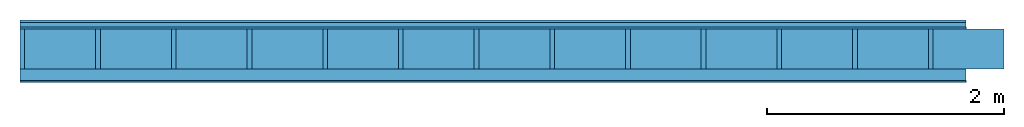
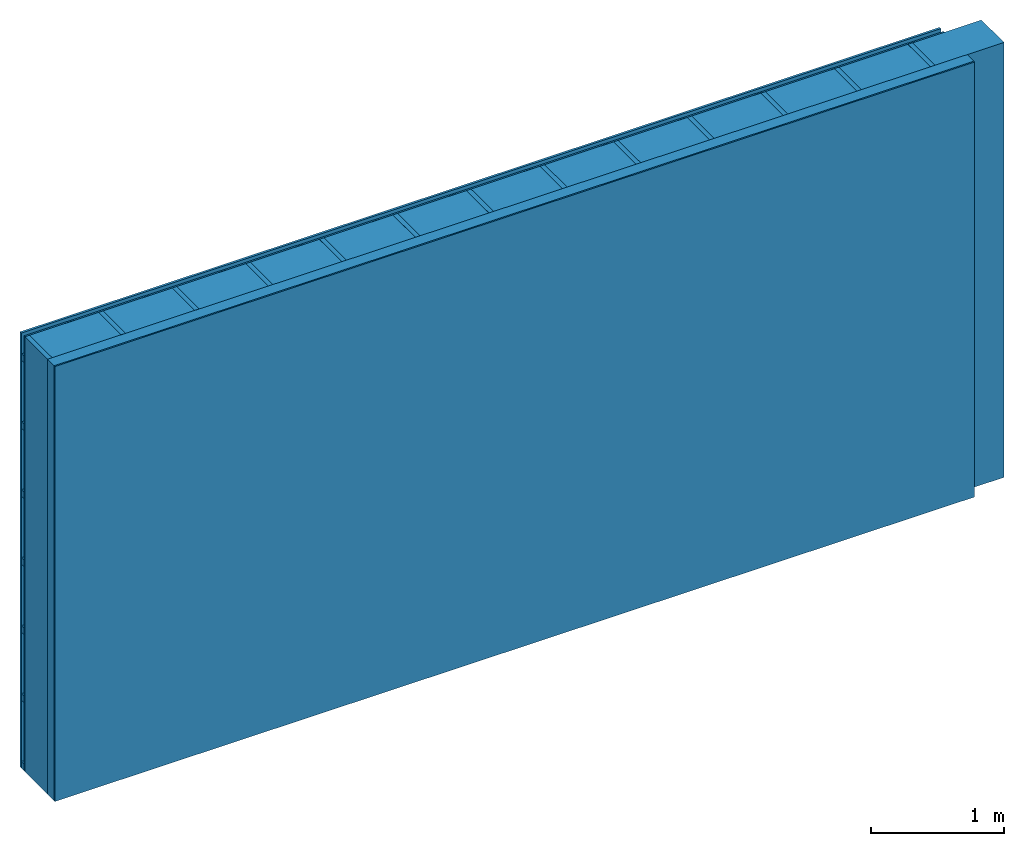
# One storey: 4 plates, 3 members, 1 element without a shape of its own.
"""IFC4 building model written with IfcOpenShell, lengths in metres."""

from ifc_helpers import new_model, si_unit, derived_unit, direction, frame, frame_2d, origin, origin_with_axes, place, context, project, spatial, rectangle, extrude, material, layer, layer_set, type_object, element, aggregate, save


model = new_model("IFC4")

# Units and contexts
plan_context = context("Plan", 3, precision=1e-05, world=origin(), true_north=direction((0.0, 1.0)))
model_context = context("Model", 3, precision=1e-05, world=origin(), true_north=direction((0.0, 1.0)))
ifc_project = project(units=[si_unit("LENGTHUNIT", "METRE"), derived_unit("SOUNDPRESSUREUNIT", [(si_unit("PRESSUREUNIT", "PASCAL", prefix="MICRO"), 0)]), si_unit("ENERGYUNIT", "JOULE", prefix="MEGA"), si_unit("MASSUNIT", "GRAM", prefix="KILO"), derived_unit("THERMALTRANSMITTANCEUNIT", [(si_unit("POWERUNIT", "WATT"), 1), (si_unit("AREAUNIT", "SQUARE_METRE"), -1), (si_unit("THERMODYNAMICTEMPERATUREUNIT", "KELVIN"), -1)]), derived_unit("AREADENSITYUNIT", [(si_unit("MASSUNIT", "GRAM", prefix="KILO"), 1), (si_unit("AREAUNIT", "SQUARE_METRE"), -1)]), derived_unit("USERDEFINED", [(si_unit("ENERGYUNIT", "JOULE", prefix="MEGA"), 1), (si_unit("AREAUNIT", "SQUARE_METRE"), -1)])], contexts=[plan_context, model_context])

# Site, building, storey
site = spatial("IfcSite", under=ifc_project)
building_placement = place(None, origin())
building = spatial("IfcBuilding", under=site, at=building_placement)
storey_placement = place(building_placement, origin())
storey = spatial("IfcBuildingStorey", under=building, at=storey_placement)

# Wall, members, plates
ifc_material_1 = material(Name="Wood cladding horizontal, closed")
ifc_layer_1 = layer(ifc_material_1, 0.02, Name="Cover 1st layer")
ifc_layer_2 = layer(None, 0.04, Name="Battens / profiles (ventilation)")
ifc_material_2 = material(Category="03.007")
ifc_layer_3 = layer(ifc_material_2, 0.015, Name="outside 1st layer")
ifc_material_3 = material(Name="of the art")
ifc_layer_4 = layer(ifc_material_3, 0.0, Name="Bond")
ifc_layer_5 = layer(None, 0.34, Name="Support")
ifc_layer_6 = layer(ifc_material_3, 0.0, Name="Bond")
ifc_material_4 = material(Name="Solid timber panel")
ifc_layer_7 = layer(ifc_material_4, 0.1, Name="1st layer")
ifc_material_5 = material(Name="Plasterboard type A", Category="03.008")
ifc_layer_8 = layer(ifc_material_5, 0.0125, Name="Covering 1st layer")
ifc_material_6 = material(Name="joints", Category="04.017")
ifc_layer_9 = layer(ifc_material_6, 0.0, Name="Surface")
ifc_layer_set = layer_set([ifc_layer_1, ifc_layer_2, ifc_layer_3, ifc_layer_4, ifc_layer_5, ifc_layer_6, ifc_layer_7, ifc_layer_8, ifc_layer_9])
wall_type = type_object("IfcWallType", Name="D0993", PredefinedType="NOTDEFINED", material=ifc_layer_set)
wall_placement = place(None, frame((0.0, 0.0, 0.0), z_axis=(0.0, -1.0, 0.0), x_axis=(1.0, 0.0, 0.0)))
wall = element("IfcWall", 1, at=wall_placement, inside=storey, type_object=wall_type, material=ifc_layer_set, Name="Wall #1")
ifc_material_7 = material()
member_1_placement = place(wall_placement, origin())
member_1 = element("IfcMember", 2, at=member_1_placement, material=ifc_material_7, Name="Battens / profiles (ventilation)", context=plan_context, shape_type="SweptSolid", body=[
    extrude(rectangle(XDim=0.06, YDim=0.04, at=frame_2d((0.03, 0.02), x_axis=(1.0, 0.0))), frame((0.0, 0.0, 0.02), z_axis=(1.0, 0.0, 0.0), x_axis=(0.0, 1.0, 0.0)), (0.0, 0.0, 1.0), 8.0),
    extrude(rectangle(XDim=0.06, YDim=0.04, at=frame_2d((0.03, 0.02), x_axis=(1.0, 0.0))), frame((0.0, 0.625, 0.02), z_axis=(1.0, 0.0, 0.0), x_axis=(0.0, 1.0, 0.0)), (0.0, 0.0, 1.0), 8.0),
    extrude(rectangle(XDim=0.06, YDim=0.04, at=frame_2d((0.03, 0.02), x_axis=(1.0, 0.0))), frame((0.0, 1.25, 0.02), z_axis=(1.0, 0.0, 0.0), x_axis=(0.0, 1.0, 0.0)), (0.0, 0.0, 1.0), 8.0),
    extrude(rectangle(XDim=0.06, YDim=0.04, at=frame_2d((0.03, 0.02), x_axis=(1.0, 0.0))), frame((0.0, 1.875, 0.02), z_axis=(1.0, 0.0, 0.0), x_axis=(0.0, 1.0, 0.0)), (0.0, 0.0, 1.0), 8.0),
    extrude(rectangle(XDim=0.06, YDim=0.04, at=frame_2d((0.03, 0.02), x_axis=(1.0, 0.0))), frame((0.0, 2.5, 0.02), z_axis=(1.0, 0.0, 0.0), x_axis=(0.0, 1.0, 0.0)), (0.0, 0.0, 1.0), 8.0),
    extrude(rectangle(XDim=0.06, YDim=0.04, at=frame_2d((0.03, 0.02), x_axis=(1.0, 0.0))), frame((0.0, 3.125, 0.02), z_axis=(1.0, 0.0, 0.0), x_axis=(0.0, 1.0, 0.0)), (0.0, 0.0, 1.0), 8.0),
    extrude(rectangle(XDim=0.06, YDim=0.04, at=frame_2d((0.03, 0.02), x_axis=(1.0, 0.0))), frame((0.0, 3.75, 0.02), z_axis=(1.0, 0.0, 0.0), x_axis=(0.0, 1.0, 0.0)), (0.0, 0.0, 1.0), 8.0),
])
ifc_material_8 = material()
member_2_placement = place(wall_placement, origin())
member_2 = element("IfcMember", 3, at=member_2_placement, material=ifc_material_8, Name="Support", context=plan_context, shape_type="SweptSolid", body=[
    extrude(rectangle(XDim=0.04, YDim=0.34, at=frame_2d((0.02, 0.17), x_axis=(1.0, 0.0))), frame((0.0, 4.0, 0.075), z_axis=(0.0, -1.0, 0.0), x_axis=(1.0, 0.0, 0.0)), (0.0, 0.0, 1.0), 4.0),
    extrude(rectangle(XDim=0.04, YDim=0.34, at=frame_2d((0.02, 0.17), x_axis=(1.0, 0.0))), frame((0.64, 4.0, 0.075), z_axis=(0.0, -1.0, 0.0), x_axis=(1.0, 0.0, 0.0)), (0.0, 0.0, 1.0), 4.0),
    extrude(rectangle(XDim=0.04, YDim=0.34, at=frame_2d((0.02, 0.17), x_axis=(1.0, 0.0))), frame((1.28, 4.0, 0.075), z_axis=(0.0, -1.0, 0.0), x_axis=(1.0, 0.0, 0.0)), (0.0, 0.0, 1.0), 4.0),
    extrude(rectangle(XDim=0.04, YDim=0.34, at=frame_2d((0.02, 0.17), x_axis=(1.0, 0.0))), frame((1.92, 4.0, 0.075), z_axis=(0.0, -1.0, 0.0), x_axis=(1.0, 0.0, 0.0)), (0.0, 0.0, 1.0), 4.0),
    extrude(rectangle(XDim=0.04, YDim=0.34, at=frame_2d((0.02, 0.17), x_axis=(1.0, 0.0))), frame((2.56, 4.0, 0.075), z_axis=(0.0, -1.0, 0.0), x_axis=(1.0, 0.0, 0.0)), (0.0, 0.0, 1.0), 4.0),
    extrude(rectangle(XDim=0.04, YDim=0.34, at=frame_2d((0.02, 0.17), x_axis=(1.0, 0.0))), frame((3.2, 4.0, 0.075), z_axis=(0.0, -1.0, 0.0), x_axis=(1.0, 0.0, 0.0)), (0.0, 0.0, 1.0), 4.0),
    extrude(rectangle(XDim=0.04, YDim=0.34, at=frame_2d((0.02, 0.17), x_axis=(1.0, 0.0))), frame((3.84, 4.0, 0.075), z_axis=(0.0, -1.0, 0.0), x_axis=(1.0, 0.0, 0.0)), (0.0, 0.0, 1.0), 4.0),
    extrude(rectangle(XDim=0.04, YDim=0.34, at=frame_2d((0.02, 0.17), x_axis=(1.0, 0.0))), frame((4.48, 4.0, 0.075), z_axis=(0.0, -1.0, 0.0), x_axis=(1.0, 0.0, 0.0)), (0.0, 0.0, 1.0), 4.0),
    extrude(rectangle(XDim=0.04, YDim=0.34, at=frame_2d((0.02, 0.17), x_axis=(1.0, 0.0))), frame((5.12, 4.0, 0.075), z_axis=(0.0, -1.0, 0.0), x_axis=(1.0, 0.0, 0.0)), (0.0, 0.0, 1.0), 4.0),
    extrude(rectangle(XDim=0.04, YDim=0.34, at=frame_2d((0.02, 0.17), x_axis=(1.0, 0.0))), frame((5.76, 4.0, 0.075), z_axis=(0.0, -1.0, 0.0), x_axis=(1.0, 0.0, 0.0)), (0.0, 0.0, 1.0), 4.0),
    extrude(rectangle(XDim=0.04, YDim=0.34, at=frame_2d((0.02, 0.17), x_axis=(1.0, 0.0))), frame((6.4, 4.0, 0.075), z_axis=(0.0, -1.0, 0.0), x_axis=(1.0, 0.0, 0.0)), (0.0, 0.0, 1.0), 4.0),
    extrude(rectangle(XDim=0.04, YDim=0.34, at=frame_2d((0.02, 0.17), x_axis=(1.0, 0.0))), frame((7.04, 4.0, 0.075), z_axis=(0.0, -1.0, 0.0), x_axis=(1.0, 0.0, 0.0)), (0.0, 0.0, 1.0), 4.0),
    extrude(rectangle(XDim=0.04, YDim=0.34, at=frame_2d((0.02, 0.17), x_axis=(1.0, 0.0))), frame((7.68, 4.0, 0.075), z_axis=(0.0, -1.0, 0.0), x_axis=(1.0, 0.0, 0.0)), (0.0, 0.0, 1.0), 4.0),
])
ifc_material_9 = material(Name="Mineral wool")
member_3_placement = place(wall_placement, origin())
member_3 = element("IfcMember", 4, at=member_3_placement, material=ifc_material_9, Name="Cavity", context=plan_context, shape_type="SweptSolid", body=[
    extrude(rectangle(XDim=0.6, YDim=0.34, at=frame_2d((0.3, 0.17), x_axis=(1.0, 0.0))), frame((0.04, 4.0, 0.075), z_axis=(0.0, -1.0, 0.0), x_axis=(1.0, 0.0, 0.0)), (0.0, 0.0, 1.0), 4.0),
    extrude(rectangle(XDim=0.6, YDim=0.34, at=frame_2d((0.3, 0.17), x_axis=(1.0, 0.0))), frame((0.68, 4.0, 0.075), z_axis=(0.0, -1.0, 0.0), x_axis=(1.0, 0.0, 0.0)), (0.0, 0.0, 1.0), 4.0),
    extrude(rectangle(XDim=0.6, YDim=0.34, at=frame_2d((0.3, 0.17), x_axis=(1.0, 0.0))), frame((1.32, 4.0, 0.075), z_axis=(0.0, -1.0, 0.0), x_axis=(1.0, 0.0, 0.0)), (0.0, 0.0, 1.0), 4.0),
    extrude(rectangle(XDim=0.6, YDim=0.34, at=frame_2d((0.3, 0.17), x_axis=(1.0, 0.0))), frame((1.96, 4.0, 0.075), z_axis=(0.0, -1.0, 0.0), x_axis=(1.0, 0.0, 0.0)), (0.0, 0.0, 1.0), 4.0),
    extrude(rectangle(XDim=0.6, YDim=0.34, at=frame_2d((0.3, 0.17), x_axis=(1.0, 0.0))), frame((2.6, 4.0, 0.075), z_axis=(0.0, -1.0, 0.0), x_axis=(1.0, 0.0, 0.0)), (0.0, 0.0, 1.0), 4.0),
    extrude(rectangle(XDim=0.6, YDim=0.34, at=frame_2d((0.3, 0.17), x_axis=(1.0, 0.0))), frame((3.24, 4.0, 0.075), z_axis=(0.0, -1.0, 0.0), x_axis=(1.0, 0.0, 0.0)), (0.0, 0.0, 1.0), 4.0),
    extrude(rectangle(XDim=0.6, YDim=0.34, at=frame_2d((0.3, 0.17), x_axis=(1.0, 0.0))), frame((3.88, 4.0, 0.075), z_axis=(0.0, -1.0, 0.0), x_axis=(1.0, 0.0, 0.0)), (0.0, 0.0, 1.0), 4.0),
    extrude(rectangle(XDim=0.6, YDim=0.34, at=frame_2d((0.3, 0.17), x_axis=(1.0, 0.0))), frame((4.52, 4.0, 0.075), z_axis=(0.0, -1.0, 0.0), x_axis=(1.0, 0.0, 0.0)), (0.0, 0.0, 1.0), 4.0),
    extrude(rectangle(XDim=0.6, YDim=0.34, at=frame_2d((0.3, 0.17), x_axis=(1.0, 0.0))), frame((5.16, 4.0, 0.075), z_axis=(0.0, -1.0, 0.0), x_axis=(1.0, 0.0, 0.0)), (0.0, 0.0, 1.0), 4.0),
    extrude(rectangle(XDim=0.6, YDim=0.34, at=frame_2d((0.3, 0.17), x_axis=(1.0, 0.0))), frame((5.8, 4.0, 0.075), z_axis=(0.0, -1.0, 0.0), x_axis=(1.0, 0.0, 0.0)), (0.0, 0.0, 1.0), 4.0),
    extrude(rectangle(XDim=0.6, YDim=0.34, at=frame_2d((0.3, 0.17), x_axis=(1.0, 0.0))), frame((6.44, 4.0, 0.075), z_axis=(0.0, -1.0, 0.0), x_axis=(1.0, 0.0, 0.0)), (0.0, 0.0, 1.0), 4.0),
    extrude(rectangle(XDim=0.6, YDim=0.34, at=frame_2d((0.3, 0.17), x_axis=(1.0, 0.0))), frame((7.08, 4.0, 0.075), z_axis=(0.0, -1.0, 0.0), x_axis=(1.0, 0.0, 0.0)), (0.0, 0.0, 1.0), 4.0),
    extrude(rectangle(XDim=0.6, YDim=0.34, at=frame_2d((0.3, 0.17), x_axis=(1.0, 0.0))), frame((7.72, 4.0, 0.075), z_axis=(0.0, -1.0, 0.0), x_axis=(1.0, 0.0, 0.0)), (0.0, 0.0, 1.0), 4.0),
])
plate_1_placement = place(wall_placement, origin())
plate_1 = element("IfcPlate", 5, at=plate_1_placement, material=ifc_material_1, Name="Cover 1st layer", context=plan_context, shape_type="SweptSolid", body=[
    extrude(rectangle(XDim=8.0, YDim=4.0, at=frame_2d((4.0, 2.0), x_axis=(1.0, 0.0))), origin_with_axes(), (0.0, 0.0, 1.0), 0.02),
])
plate_2_placement = place(wall_placement, origin())
plate_2 = element("IfcPlate", 6, at=plate_2_placement, material=ifc_material_2, Name="outside 1st layer", context=plan_context, shape_type="SweptSolid", body=[
    extrude(rectangle(XDim=8.0, YDim=4.0, at=frame_2d((4.0, 2.0), x_axis=(1.0, 0.0))), frame((0.0, 0.0, 0.06), z_axis=(0.0, 0.0, 1.0), x_axis=(1.0, 0.0, 0.0)), (0.0, 0.0, 1.0), 0.015),
])
plate_3_placement = place(wall_placement, origin())
plate_3 = element("IfcPlate", 7, at=plate_3_placement, material=ifc_material_4, Name="1st layer", context=plan_context, shape_type="SweptSolid", body=[
    extrude(rectangle(XDim=8.0, YDim=4.0, at=frame_2d((4.0, 2.0), x_axis=(1.0, 0.0))), frame((0.0, 0.0, 0.415), z_axis=(0.0, 0.0, 1.0), x_axis=(1.0, 0.0, 0.0)), (0.0, 0.0, 1.0), 0.1),
])
plate_4_placement = place(wall_placement, origin())
plate_4 = element("IfcPlate", 8, at=plate_4_placement, material=ifc_material_5, Name="Covering 1st layer", context=plan_context, shape_type="SweptSolid", body=[
    extrude(rectangle(XDim=8.0, YDim=4.0, at=frame_2d((4.0, 2.0), x_axis=(1.0, 0.0))), frame((0.0, 0.0, 0.515), z_axis=(0.0, 0.0, 1.0), x_axis=(1.0, 0.0, 0.0)), (0.0, 0.0, 1.0), 0.0125),
])
aggregate(wall, [plate_1, member_1, plate_2, member_2, member_3, plate_3, plate_4])

save(model, "model.ifc")
